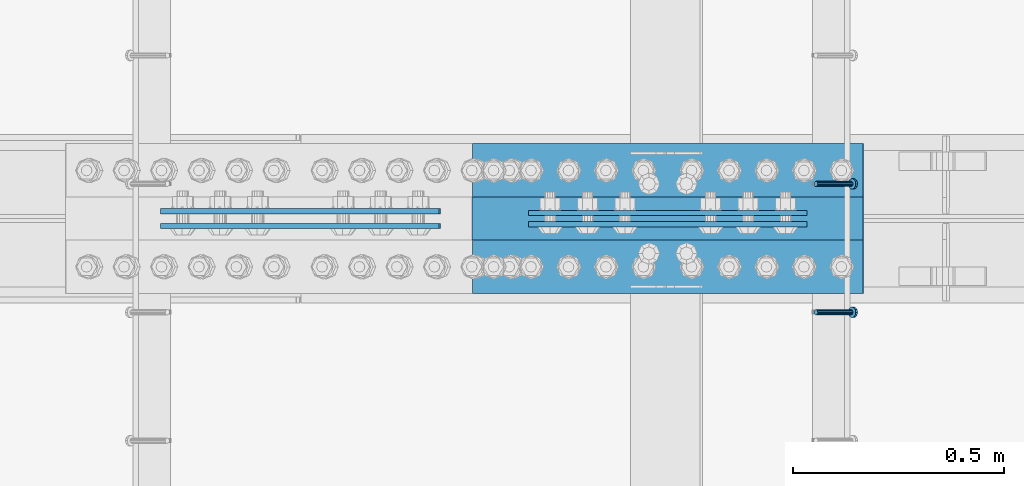
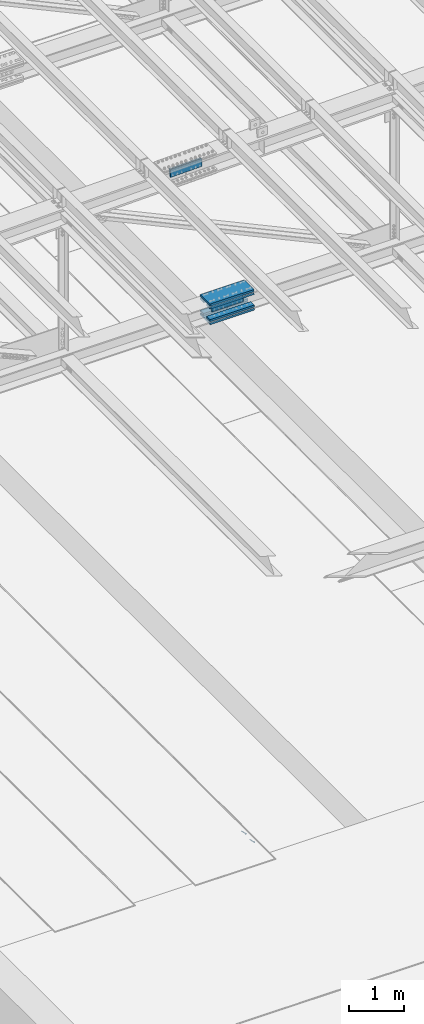
# One storey, part 2426 of 3843: 10 beams, 2 members, 3 elements without a shape of their own.
"""IFC2X3 building model written with IfcOpenShell, lengths in millimetres."""

import ifcopenshell
import ifcopenshell.guid

model = None  # the IFC model being written
_history = None  # IfcOwnerHistory: only IFC2X3 demands one
_inside = {}  # id of a spatial element -> (the spatial element, [elements in it])
_under = {}  # id of a project, library or spatial element -> (it, [spatial elements below it])
_declared = {}  # id of a project -> (the project, [libraries it declares])
_typed = {}  # id of a type object -> (the type object, [elements of that type])
_made_of = {}  # id of a material, layer set ... -> (it, [elements and type objects made of it])


def new_model(schema):
    """Start an empty IFC model of exactly this schema.

    Asked for "IFC4X3", IfcOpenShell would pick the latest addendum, in which some entities
    have other attributes; the version numbers below select the first issue.
    IFC2X3 requires an IfcOwnerHistory on every rooted entity: one is made here for all.
    """
    global model, _history
    if schema == "IFC4X3":
        model = ifcopenshell.file(schema_version=(4, 3, 0, 0))
    else:
        model = ifcopenshell.file(schema=schema)
    _inside.clear()
    _under.clear()
    _declared.clear()
    _typed.clear()
    _made_of.clear()
    _history = None
    if model.schema == "IFC2X3":
        org = make("IfcOrganization", Name="unknown")
        user = make(
            "IfcPersonAndOrganization",
            ThePerson=make("IfcPerson", FamilyName="unknown"),
            TheOrganization=org,
        )
        app = make(
            "IfcApplication",
            ApplicationDeveloper=org,
            Version="unknown",
            ApplicationFullName="unknown",
            ApplicationIdentifier="unknown",
        )
        _history = make(
            "IfcOwnerHistory",
            OwningUser=user,
            OwningApplication=app,
            ChangeAction="ADDED",
            CreationDate=0,
        )
    return model


def make(cls, **values):
    """One entity of the class cls with the attributes given. An attribute that is None is left unset."""
    return model.create_entity(
        cls, **{name: value for name, value in values.items() if value is not None}
    )


def rooted(cls, **values):
    """An entity with a GlobalId (a new one), such as an element, a storey or a relation."""
    return make(cls, GlobalId=ifcopenshell.guid.new(), OwnerHistory=_history, **values)


def si_unit(unit_type, name, prefix=None):
    """IfcSIUnit, for example si_unit("LENGTHUNIT", "METRE", prefix="MILLI")."""
    return make("IfcSIUnit", UnitType=unit_type, Prefix=prefix, Name=name)


def assignment(units):
    """IfcUnitAssignment: the units of a project."""
    return None if units is None else make("IfcUnitAssignment", Units=units)


def point(xyz):
    """IfcCartesianPoint."""
    return None if xyz is None else make("IfcCartesianPoint", Coordinates=xyz)


def direction(xyz):
    """IfcDirection."""
    return None if xyz is None else make("IfcDirection", DirectionRatios=xyz)


def frame(location, z_axis=None, x_axis=None):
    """IfcAxis2Placement3D, a coordinate frame: its origin and axes. An axis left out is left unset."""
    return make(
        "IfcAxis2Placement3D",
        Location=point(location),
        Axis=direction(z_axis),
        RefDirection=direction(x_axis),
    )


def origin_with_axes():
    """The frame at (0, 0, 0) with the z axis (0, 0, 1) and the x axis (1, 0, 0) written out."""
    return frame((0.0, 0.0, 0.0), z_axis=(0.0, 0.0, 1.0), x_axis=(1.0, 0.0, 0.0))


def place(relative_to, where):
    """IfcLocalPlacement: puts the frame where relative to a parent placement (None: the world)."""
    return make(
        "IfcLocalPlacement", PlacementRelTo=relative_to, RelativePlacement=where
    )


def context(
    kind, dimensions, precision=None, world=None, true_north=None, identifier=None
):
    """IfcGeometricRepresentationContext, for example the 3D "Model" context."""
    return make(
        "IfcGeometricRepresentationContext",
        ContextIdentifier=identifier,
        ContextType=kind,
        CoordinateSpaceDimension=dimensions,
        Precision=precision,
        WorldCoordinateSystem=world,
        TrueNorth=true_north,
    )


def subcontext(parent, identifier, kind, view, scale=None):
    """IfcGeometricRepresentationSubContext, for example "Body" below "Model"."""
    return make(
        "IfcGeometricRepresentationSubContext",
        ContextIdentifier=identifier,
        ContextType=kind,
        ParentContext=parent,
        TargetScale=scale,
        TargetView=view,
    )


def project(units=None, contexts=None):
    """IfcProject with its units and contexts."""
    return rooted(
        "IfcProject",
        Name="project",
        RepresentationContexts=contexts,
        UnitsInContext=assignment(units),
    )


def spatial(cls, under=None, at=None, **own):
    """A site, building, storey or space (cls), placed at a placement, below another one or the project."""
    s = rooted(cls, ObjectPlacement=at, **own)
    if under is not None:
        _under.setdefault(under.id(), (under, []))[1].append(s)
    return s


def faces_of(points, faces, orient=None, outer=None):
    """IfcFace entities. A face is a list of loops; a loop is a list of indices into points, from 0.

    orient and outer hold one flag for each loop. By default every Orientation is true, the
    first loop of a face is its IfcFaceOuterBound and the others are IfcFaceBound.
    """
    made = []
    for i, loops in enumerate(faces):
        bounds = []
        for j, loop in enumerate(loops):
            is_outer = j == 0 if outer is None else outer[i][j]
            bounds.append(
                make(
                    "IfcFaceOuterBound" if is_outer else "IfcFaceBound",
                    Bound=make("IfcPolyLoop", Polygon=[points[k] for k in loop]),
                    Orientation=True if orient is None else orient[i][j],
                )
            )
        made.append(make("IfcFace", Bounds=bounds))
    return made


def faceted_brep(points, faces, orient=None, outer=None, voids=None):
    """IfcFacetedBrep: a solid bounded by flat faces; with voids (closed shells), ...WithVoids."""
    shared = [point(p) for p in points]
    hull = make("IfcClosedShell", CfsFaces=faces_of(shared, faces, orient, outer))
    if voids is None:
        return make("IfcFacetedBrep", Outer=hull)
    return make(
        "IfcFacetedBrepWithVoids",
        Outer=hull,
        Voids=[
            make(cls, CfsFaces=faces_of(shared, fs, o, b)) for cls, fs, o, b in voids
        ],
    )


def shape(context_of_items, identifier, shape_type, items):
    """IfcShapeRepresentation: the items that make up one representation, for example the "Body"."""
    return make(
        "IfcShapeRepresentation",
        ContextOfItems=context_of_items,
        RepresentationIdentifier=identifier,
        RepresentationType=shape_type,
        Items=items,
    )


def material(Name=None, Category=None):
    """IfcMaterial."""
    return make("IfcMaterial", Name=Name, Category=Category)


def made_of(thing, what):
    """Note that an element or type object is made of a material, layer set ...; save() writes the relation."""
    if what is not None:
        _made_of.setdefault(what.id(), (what, []))[1].append(thing)
    return thing


def type_object(cls, material=None, **own):
    """A type object (cls), such as IfcWallType, which elements share."""
    return made_of(rooted(cls, **own), material)


def element(
    cls,
    number,
    at=None,
    inside=None,
    cuts=None,
    type_object=None,
    material=None,
    context=None,
    identifier="Body",
    shape_type=None,
    held_by="IfcProductDefinitionShape",
    body=None,
    shapes=None,
    **own,
):
    """One element of the class cls, such as IfcWall. Its Tag is "e" and its number.

    at: its placement. inside: the storey or other place that contains it. cuts: it is an
    opening in that element (IfcRelVoidsElement). A single representation is given by context,
    identifier, shape_type and body (its items); several are given by shapes. held_by: the class
    of the entity that holds the representations. save() writes the other relations.
    """
    e = rooted(cls, Tag="e%d" % number, ObjectPlacement=at, **own)
    if body is not None:
        shapes = [shape(context, identifier, shape_type, body)]
    if shapes is not None:
        e.Representation = make(held_by, Representations=shapes)
    if inside is not None:
        _inside.setdefault(inside.id(), (inside, []))[1].append(e)
    if cuts is not None:
        rooted(
            "IfcRelVoidsElement", RelatingBuildingElement=cuts, RelatedOpeningElement=e
        )
    if type_object is not None:
        _typed.setdefault(type_object.id(), (type_object, []))[1].append(e)
    return made_of(e, material)


def aggregate(whole, parts):
    """IfcRelAggregates: a whole, such as a stair, and the parts it consists of."""
    return rooted("IfcRelAggregates", RelatingObject=whole, RelatedObjects=parts)


def save(model, path):
    """Write the relations noted so far, then the file.

    IfcRelAggregates (storeys below a building ...), IfcRelContainedInSpatialStructure (elements
    in a storey), IfcRelDefinesByType, IfcRelAssociatesMaterial and IfcRelDeclares: one each for
    every whole, place, type object, material and project.
    """
    for whole, parts in _under.values():
        aggregate(whole, parts)
    for where, things in _inside.values():
        rooted(
            "IfcRelContainedInSpatialStructure",
            RelatedElements=things,
            RelatingStructure=where,
        )
    for kind, things in _typed.values():
        rooted("IfcRelDefinesByType", RelatedObjects=things, RelatingType=kind)
    for what, things in _made_of.values():
        rooted("IfcRelAssociatesMaterial", RelatedObjects=things, RelatingMaterial=what)
    for by, libraries in _declared.values():
        rooted("IfcRelDeclares", RelatingContext=by, RelatedDefinitions=libraries)
    model.write(path)


model = new_model("IFC2X3")

# Units and contexts
model_context = context("Model", 3, precision=1e-05, world=origin_with_axes())
body_context = subcontext(model_context, "Body", "Model", "MODEL_VIEW")
ifc_project = project(units=[si_unit("LENGTHUNIT", "METRE", prefix="MILLI"), si_unit("AREAUNIT", "SQUARE_METRE"), si_unit("VOLUMEUNIT", "CUBIC_METRE"), si_unit("MASSUNIT", "GRAM", prefix="KILO"), si_unit("TIMEUNIT", "SECOND"), si_unit("PLANEANGLEUNIT", "RADIAN"), si_unit("SOLIDANGLEUNIT", "STERADIAN"), si_unit("THERMODYNAMICTEMPERATUREUNIT", "DEGREE_CELSIUS"), si_unit("LUMINOUSINTENSITYUNIT", "LUMEN")], contexts=[model_context])

# Site, building, storey
site_placement = place(None, origin_with_axes())
site = spatial("IfcSite", under=ifc_project, at=site_placement, CompositionType="ELEMENT")
building_placement = place(site_placement, origin_with_axes())
building = spatial("IfcBuilding", under=site, at=building_placement, Name="Undefined", CompositionType="ELEMENT")
storey_placement = place(building_placement, origin_with_axes())
storey = spatial("IfcBuildingStorey", under=building, at=storey_placement, Name="Undefined", CompositionType="ELEMENT", Elevation=0.0)

# Assembly, members
assembly_1_placement = place(storey_placement, origin_with_axes())
assembly_1 = element("IfcElementAssembly", 1, at=assembly_1_placement, inside=storey, Name="EMBED_ANGLE", AssemblyPlace="NOTDEFINED", PredefinedType="RIGID_FRAME")
ifc_material_1 = material(Name="STEEL/A108")
member_type = type_object("IfcMemberType", PredefinedType="NOTDEFINED")
member_1_placement = place(assembly_1_placement, frame((52815.2995, 67049.649703125, 30446.6625), z_axis=(0.0, 1.0, 0.0), x_axis=(0.707106781186548, 0.0, -0.707106781186548)))
member_1 = element("IfcMember", 2, at=member_1_placement, type_object=member_type, material=ifc_material_1, Name="HEADED STUD ANCHOR", context=body_context, shape_type="Brep", body=[
    faceted_brep([(7.27595761418343e-12, -3.18000006675175, 5.5), (0.0, -5.49999999998363, 3.1800000667572), (118.110000000976, -5.49999999999091, 3.1800000667572), (118.110000000983, -3.18000006675175, 5.5), (0.0, -6.3499999046162, 0.0), (118.110000000968, -6.34999990461256, 0.0), (0.0, -5.49999999998363, -3.1800000667572), (118.110000000976, -5.49999999999091, -3.1800000667572), (7.27595761418343e-12, -3.18000006675175, -5.5), (118.110000000983, -3.18000006675175, -5.5), (7.27595761418343e-12, -1.81898940354586e-12, -6.34999990463257), (118.110000000968, -1.81898940354586e-12, -6.34999990463257), (0.0, 3.18000006675175, -5.5), (118.110000000968, 3.18000006674811, -5.5), (7.27595761418343e-12, 5.49999999998363, -3.1800000667572), (118.110000000983, 5.49999999998363, -3.1800000667572), (7.27595761418343e-12, 6.3499999046162, 0.0), (118.110000000976, 6.34999990461256, 0.0), (7.27595761418343e-12, 5.49999999998363, 3.1800000667572), (118.110000000983, 5.49999999998363, 3.1800000667572), (0.0, 3.18000006675175, 5.5), (118.110000000968, 3.18000006674811, 5.5), (7.27595761418343e-12, -1.81898940354586e-12, 6.34999990463257), (118.110000000968, -1.81898940354586e-12, 6.34999990463257), (120.650000000991, -10.9899997710909, 6.34999990463257), (120.650000000998, -6.34000015257152, 10.9899997711182), (120.650000000991, -12.6999998092379, 0.0), (120.650000000991, -10.9899997710909, -6.34999990463257), (120.650000000998, -6.34000015257152, -10.9899997711182), (120.650000000991, -1.81898940354586e-12, -12.6899995803833), (120.650000000991, 6.34000015257152, -10.9899997711182), (120.650000000998, 10.9899997710909, -6.34999990463257), (120.650000000991, 12.6999998092342, 0.0), (120.650000000998, 10.9899997710909, 6.34999990463257), (120.650000000991, 6.34000015257152, 10.9899997711182), (120.650000000991, -1.81898940354586e-12, 12.6899995803833), (127.000000001048, -10.9899997710945, 6.34999990463257), (127.000000001048, -6.34000015257152, 10.9899997711182), (127.000000001048, -12.6999998092342, 0.0), (127.000000001048, -10.9899997710945, -6.34999990463257), (127.000000001048, -6.34000015257152, -10.9899997711182), (127.000000001048, 1.81898940354586e-12, -12.6899995803833), (127.000000001048, 6.34000015256788, -10.9899997711182), (127.000000001048, 10.9899997710909, -6.34999990463257), (127.000000001048, 12.6999998092379, 0.0), (127.000000001048, 10.9899997710909, 6.34999990463257), (127.000000001048, 6.34000015256788, 10.9899997711182), (127.000000001048, 1.81898940354586e-12, 12.6899995803833)], [[[0, 1, 2, 3]], [[1, 4, 5, 2]], [[4, 6, 7, 5]], [[6, 8, 9, 7]], [[8, 10, 11, 9]], [[10, 12, 13, 11]], [[12, 14, 15, 13]], [[14, 16, 17, 15]], [[16, 18, 19, 17]], [[18, 20, 21, 19]], [[20, 22, 23, 21]], [[22, 0, 3, 23]], [[22, 20, 18, 16, 14, 12, 10, 8, 6, 4, 1, 0]], [[3, 2, 24, 25]], [[2, 5, 26, 24]], [[5, 7, 27, 26]], [[7, 9, 28, 27]], [[9, 11, 29, 28]], [[11, 13, 30, 29]], [[13, 15, 31, 30]], [[15, 17, 32, 31]], [[17, 19, 33, 32]], [[19, 21, 34, 33]], [[21, 23, 35, 34]], [[23, 3, 25, 35]], [[25, 24, 36, 37]], [[24, 26, 38, 36]], [[26, 27, 39, 38]], [[27, 28, 40, 39]], [[28, 29, 41, 40]], [[29, 30, 42, 41]], [[30, 31, 43, 42]], [[31, 32, 44, 43]], [[32, 33, 45, 44]], [[33, 34, 46, 45]], [[34, 35, 47, 46]], [[35, 25, 37, 47]], [[38, 39, 40, 41, 42, 43, 44, 45, 46, 47, 37, 36]]]),
])
member_2_placement = place(assembly_1_placement, frame((52815.2995, 67354.449703125, 30446.6625), z_axis=(0.0, 1.0, 0.0), x_axis=(0.707106781186548, 0.0, -0.707106781186548)))
member_2 = element("IfcMember", 3, at=member_2_placement, type_object=member_type, material=ifc_material_1, Name="HEADED STUD ANCHOR", context=body_context, shape_type="Brep", body=[
    faceted_brep([(7.27595761418343e-12, -3.18000006675175, 5.5), (0.0, -5.49999999998363, 3.1800000667572), (118.110000000976, -5.49999999999091, 3.1800000667572), (118.110000000983, -3.18000006675175, 5.5), (0.0, -6.3499999046162, 0.0), (118.110000000968, -6.34999990461256, 0.0), (0.0, -5.49999999998363, -3.1800000667572), (118.110000000976, -5.49999999999091, -3.1800000667572), (7.27595761418343e-12, -3.18000006675175, -5.5), (118.110000000983, -3.18000006675175, -5.5), (7.27595761418343e-12, -1.81898940354586e-12, -6.34999990463257), (118.110000000968, -1.81898940354586e-12, -6.34999990463257), (0.0, 3.18000006675175, -5.5), (118.110000000968, 3.18000006674811, -5.5), (7.27595761418343e-12, 5.49999999998363, -3.1800000667572), (118.110000000983, 5.49999999998363, -3.1800000667572), (7.27595761418343e-12, 6.3499999046162, 0.0), (118.110000000976, 6.34999990461256, 0.0), (7.27595761418343e-12, 5.49999999998363, 3.1800000667572), (118.110000000983, 5.49999999998363, 3.1800000667572), (0.0, 3.18000006675175, 5.5), (118.110000000968, 3.18000006674811, 5.5), (7.27595761418343e-12, -1.81898940354586e-12, 6.34999990463257), (118.110000000968, -1.81898940354586e-12, 6.34999990463257), (120.650000000991, -10.9899997710909, 6.34999990463257), (120.650000000998, -6.34000015257152, 10.9899997711182), (120.650000000991, -12.6999998092379, 0.0), (120.650000000991, -10.9899997710909, -6.34999990463257), (120.650000000998, -6.34000015257152, -10.9899997711182), (120.650000000991, -1.81898940354586e-12, -12.6899995803833), (120.650000000991, 6.34000015257152, -10.9899997711182), (120.650000000998, 10.9899997710909, -6.34999990463257), (120.650000000991, 12.6999998092342, 0.0), (120.650000000998, 10.9899997710909, 6.34999990463257), (120.650000000991, 6.34000015257152, 10.9899997711182), (120.650000000991, -1.81898940354586e-12, 12.6899995803833), (127.000000001048, -10.9899997710945, 6.34999990463257), (127.000000001048, -6.34000015257152, 10.9899997711182), (127.000000001048, -12.6999998092342, 0.0), (127.000000001048, -10.9899997710945, -6.34999990463257), (127.000000001048, -6.34000015257152, -10.9899997711182), (127.000000001048, 1.81898940354586e-12, -12.6899995803833), (127.000000001048, 6.34000015256788, -10.9899997711182), (127.000000001048, 10.9899997710909, -6.34999990463257), (127.000000001048, 12.6999998092379, 0.0), (127.000000001048, 10.9899997710909, 6.34999990463257), (127.000000001048, 6.34000015256788, 10.9899997711182), (127.000000001048, 1.81898940354586e-12, 12.6899995803833)], [[[0, 1, 2, 3]], [[1, 4, 5, 2]], [[4, 6, 7, 5]], [[6, 8, 9, 7]], [[8, 10, 11, 9]], [[10, 12, 13, 11]], [[12, 14, 15, 13]], [[14, 16, 17, 15]], [[16, 18, 19, 17]], [[18, 20, 21, 19]], [[20, 22, 23, 21]], [[22, 0, 3, 23]], [[22, 20, 18, 16, 14, 12, 10, 8, 6, 4, 1, 0]], [[3, 2, 24, 25]], [[2, 5, 26, 24]], [[5, 7, 27, 26]], [[7, 9, 28, 27]], [[9, 11, 29, 28]], [[11, 13, 30, 29]], [[13, 15, 31, 30]], [[15, 17, 32, 31]], [[17, 19, 33, 32]], [[19, 21, 34, 33]], [[21, 23, 35, 34]], [[23, 3, 25, 35]], [[25, 24, 36, 37]], [[24, 26, 38, 36]], [[26, 27, 39, 38]], [[27, 28, 40, 39]], [[28, 29, 41, 40]], [[29, 30, 42, 41]], [[30, 31, 43, 42]], [[31, 32, 44, 43]], [[32, 33, 45, 44]], [[33, 34, 46, 45]], [[34, 35, 47, 46]], [[35, 25, 37, 47]], [[38, 39, 40, 41, 42, 43, 44, 45, 46, 47, 37, 36]]]),
])
aggregate(assembly_1, [member_1, member_2])

# Assembly, beam
assembly_2_placement = place(storey_placement, origin_with_axes())
assembly_2 = element("IfcElementAssembly", 4, at=assembly_2_placement, inside=storey, Name="BEAM", AssemblyPlace="NOTDEFINED", PredefinedType="RIGID_FRAME")
ifc_material_2 = material(Name="STEEL/A572-50")
beam_type_1 = type_object("IfcBeamType", PredefinedType="NOTDEFINED")
beam_1_placement = place(assembly_2_placement, frame((52793.8984726078, 67258.40625, 42320.5850515071), z_axis=(0.00308226299943634, 0.0, -0.999995249816119), x_axis=(-0.999995249816119, 0.0, -0.00308226299943732)))
beam_1 = element("IfcBeam", 5, at=beam_1_placement, type_object=beam_type_1, material=ifc_material_2, Name="PLATE", context=body_context, shape_type="Brep", body=[
    faceted_brep([(1.45519152283669e-11, 6.35000000000582, -88.8999999998996), (0.0, 6.34999999999854, 88.9000015258789), (660.399999982677, 6.35000000000582, 88.8999999999651), (660.399999982707, 6.35000000000582, -88.8999999998268), (0.0, -6.34999999999854, 88.9000015258789), (660.399999982677, -6.35000000000582, 88.8999999999651), (1.45519152283669e-11, -6.35000000000582, -88.8999999998996), (660.399999982707, -6.35000000000582, -88.8999999998268)], [[[0, 1, 2, 3]], [[1, 4, 5, 2]], [[4, 6, 7, 5]], [[6, 0, 3, 7]], [[5, 7, 3, 2]], [[6, 4, 1, 0]]]),
])

# Assembly, beams
assembly_3_placement = place(storey_placement, origin_with_axes())
assembly_3 = element("IfcElementAssembly", 6, at=assembly_3_placement, inside=storey, Name="BEAM", AssemblyPlace="NOTDEFINED", PredefinedType="RIGID_FRAME")
beam_2_placement = place(assembly_3_placement, frame((51922.3046035143, 67289.3625, 45617.4714041232), z_axis=(0.0243978430079077, 0.0, -0.999702328324067), x_axis=(-0.999702328324067, 0.0, -0.024397843007905)))
beam_2 = element("IfcBeam", 7, at=beam_2_placement, type_object=beam_type_1, material=ifc_material_2, Name="PLATE", context=body_context, shape_type="Brep", body=[
    faceted_brep([(1.45519152283669e-11, 6.35000000000582, -88.8999999998996), (0.0, 6.34999999999854, 88.9000015258789), (660.399999982677, 6.35000000000582, 88.8999999999651), (660.399999982707, 6.35000000000582, -88.8999999998268), (0.0, -6.34999999999854, 88.9000015258789), (660.399999982677, -6.35000000000582, 88.8999999999651), (1.45519152283669e-11, -6.35000000000582, -88.8999999998996), (660.399999982707, -6.35000000000582, -88.8999999998268)], [[[0, 1, 2, 3]], [[1, 4, 5, 2]], [[4, 6, 7, 5]], [[6, 0, 3, 7]], [[5, 7, 3, 2]], [[6, 4, 1, 0]]]),
])
beam_3_placement = place(assembly_3_placement, frame((51922.3046035143, 67254.4375, 45617.4714041232), z_axis=(0.0243978430079077, 0.0, -0.999702328324067), x_axis=(-0.999702328324067, 0.0, -0.024397843007905)))
beam_3 = element("IfcBeam", 8, at=beam_3_placement, type_object=beam_type_1, material=ifc_material_2, Name="PLATE", context=body_context, shape_type="Brep", body=[
    faceted_brep([(1.45519152283669e-11, 6.35000000000582, -88.8999999998996), (0.0, 6.34999999999854, 88.9000015258789), (660.399999982677, 6.35000000000582, 88.8999999999651), (660.399999982707, 6.35000000000582, -88.8999999998268), (0.0, -6.34999999999854, 88.9000015258789), (660.399999982677, -6.35000000000582, 88.8999999999651), (1.45519152283669e-11, -6.35000000000582, -88.8999999998996), (660.399999982707, -6.35000000000582, -88.8999999998268)], [[[0, 1, 2, 3]], [[1, 4, 5, 2]], [[4, 6, 7, 5]], [[6, 0, 3, 7]], [[5, 7, 3, 2]], [[6, 4, 1, 0]]]),
])
aggregate(assembly_3, [beam_2, beam_3])

# Beam
beam_4_placement = place(assembly_2_placement, frame((52793.8984726078, 67285.39375, 42320.5850515071), z_axis=(0.00308226299943634, 0.0, -0.999995249816119), x_axis=(-0.999995249816119, 0.0, -0.00308226299943732)))
beam_4 = element("IfcBeam", 9, at=beam_4_placement, type_object=beam_type_1, material=ifc_material_2, Name="PLATE", context=body_context, shape_type="Brep", body=[
    faceted_brep([(1.45519152283669e-11, 6.35000000000582, -88.8999999998996), (0.0, 6.34999999999854, 88.9000015258789), (660.399999982677, 6.35000000000582, 88.8999999999651), (660.399999982707, 6.35000000000582, -88.8999999998268), (0.0, -6.34999999999854, 88.9000015258789), (660.399999982677, -6.35000000000582, 88.8999999999651), (1.45519152283669e-11, -6.35000000000582, -88.8999999998996), (660.399999982707, -6.35000000000582, -88.8999999998268)], [[[0, 1, 2, 3]], [[1, 4, 5, 2]], [[4, 6, 7, 5]], [[6, 0, 3, 7]], [[5, 7, 3, 2]], [[6, 4, 1, 0]]]),
])

beam_type_2 = type_object("IfcBeamType", PredefinedType="NOTDEFINED")
beam_5_placement = place(assembly_2_placement, frame((52926.6117401026, 67271.9, 42527.3691308405), z_axis=(0.0, -1.0, 0.0), x_axis=(-0.999995249816119, 0.0, -0.00308226299943732)))
beam_5 = element("IfcBeam", 10, at=beam_5_placement, type_object=beam_type_2, material=ifc_material_2, Name="PLATE", context=body_context, shape_type="Brep", body=[
    faceted_brep([(0.0, 22.2249999999767, -177.800000000003), (0.0, 22.2249999999767, 177.800000000003), (927.099999958984, 22.2250000000859, 177.800000000003), (927.099999958984, 22.2250000000859, -177.800000000003), (0.0, -22.2249999999694, 177.800000000003), (927.099999958984, -22.2249999998749, 177.800000000003), (0.0, -22.2249999999694, -177.800000000003), (927.099999958984, -22.2249999998749, -177.800000000003)], [[[0, 1, 2, 3]], [[1, 4, 5, 2]], [[4, 6, 7, 5]], [[6, 0, 3, 7]], [[5, 7, 3, 2]], [[6, 4, 1, 0]]]),
])

beam_6_placement = place(assembly_2_placement, frame((52927.8875456511, 67271.9, 42114.5544722647), z_axis=(0.0, -1.0, 0.0), x_axis=(-0.999995249816119, 0.0, -0.00308226299943732)))
beam_6 = element("IfcBeam", 11, at=beam_6_placement, type_object=beam_type_2, material=ifc_material_2, Name="PLATE", context=body_context, shape_type="Brep", body=[
    faceted_brep([(0.0, 22.2249999999767, -177.800000000003), (0.0, 22.2249999999767, 177.800000000003), (927.099999958984, 22.2250000000859, 177.800000000003), (927.099999958984, 22.2250000000859, -177.800000000003), (0.0, -22.2249999999694, 177.800000000003), (927.099999958984, -22.2249999998749, 177.800000000003), (0.0, -22.2249999999694, -177.800000000003), (927.099999958984, -22.2249999998749, -177.800000000003)], [[[0, 1, 2, 3]], [[1, 4, 5, 2]], [[4, 6, 7, 5]], [[6, 0, 3, 7]], [[5, 7, 3, 2]], [[6, 4, 1, 0]]]),
])

beam_type_3 = type_object("IfcBeamType", PredefinedType="NOTDEFINED")
beam_7_placement = place(assembly_2_placement, frame((51999.7267600347, 67386.2, 42456.1802609551), z_axis=(0.0, -1.0, 0.0), x_axis=(0.999995249816119, 0.0, 0.00308226299943554)))
beam_7 = element("IfcBeam", 12, at=beam_7_placement, type_object=beam_type_3, material=ifc_material_2, Name="PLATE", context=body_context, shape_type="Brep", body=[
    faceted_brep([(-7.27595761418343e-11, 22.2250000000786, -63.5), (-7.27595761418343e-11, 22.2250000000786, 63.5), (927.099999951592, 22.2250000031054, 63.5), (927.099999951592, 22.2250000031054, -63.5), (6.54836185276508e-11, -22.2250000000713, 63.5), (927.099999951744, -22.2249999970372, 63.5), (6.54836185276508e-11, -22.2250000000713, -63.5), (927.099999951744, -22.2249999970372, -63.5)], [[[0, 1, 2, 3]], [[1, 4, 5, 2]], [[4, 6, 7, 5]], [[6, 0, 3, 7]], [[5, 7, 3, 2]], [[6, 4, 1, 0]]]),
])

beam_8_placement = place(assembly_2_placement, frame((52000.5781504334, 67386.2, 42179.9590719878), z_axis=(0.0, -1.0, 0.0), x_axis=(0.999995249816119, 0.0, 0.00308226299943554)))
beam_8 = element("IfcBeam", 13, at=beam_8_placement, type_object=beam_type_3, material=ifc_material_2, Name="PLATE", context=body_context, shape_type="Brep", body=[
    faceted_brep([(-7.27595761418343e-11, 22.2250000000786, -63.5), (-7.27595761418343e-11, 22.2250000000786, 63.5), (927.099999951592, 22.2250000031054, 63.5), (927.099999951592, 22.2250000031054, -63.5), (6.54836185276508e-11, -22.2250000000713, 63.5), (927.099999951744, -22.2249999970372, 63.5), (6.54836185276508e-11, -22.2250000000713, -63.5), (927.099999951744, -22.2249999970372, -63.5)], [[[0, 1, 2, 3]], [[1, 4, 5, 2]], [[4, 6, 7, 5]], [[6, 0, 3, 7]], [[5, 7, 3, 2]], [[6, 4, 1, 0]]]),
])

beam_9_placement = place(assembly_2_placement, frame((51999.7267600347, 67157.6, 42456.1802609551), z_axis=(0.0, -1.0, 0.0), x_axis=(0.999995249816119, 0.0, 0.00308226299943554)))
beam_9 = element("IfcBeam", 14, at=beam_9_placement, type_object=beam_type_3, material=ifc_material_2, Name="PLATE", context=body_context, shape_type="Brep", body=[
    faceted_brep([(-7.27595761418343e-11, 22.2250000000786, -63.5), (-7.27595761418343e-11, 22.2250000000786, 63.5), (927.099999951592, 22.2250000031054, 63.5), (927.099999951592, 22.2250000031054, -63.5), (6.54836185276508e-11, -22.2250000000713, 63.5), (927.099999951744, -22.2249999970372, 63.5), (6.54836185276508e-11, -22.2250000000713, -63.5), (927.099999951744, -22.2249999970372, -63.5)], [[[0, 1, 2, 3]], [[1, 4, 5, 2]], [[4, 6, 7, 5]], [[6, 0, 3, 7]], [[5, 7, 3, 2]], [[6, 4, 1, 0]]]),
])

beam_10_placement = place(assembly_2_placement, frame((52000.5781504334, 67157.6, 42179.9590719878), z_axis=(0.0, -1.0, 0.0), x_axis=(0.999995249816119, 0.0, 0.00308226299943554)))
beam_10 = element("IfcBeam", 15, at=beam_10_placement, type_object=beam_type_3, material=ifc_material_2, Name="PLATE", context=body_context, shape_type="Brep", body=[
    faceted_brep([(-7.27595761418343e-11, 22.2250000000786, -63.5), (-7.27595761418343e-11, 22.2250000000786, 63.5), (927.099999951592, 22.2250000031054, 63.5), (927.099999951592, 22.2250000031054, -63.5), (6.54836185276508e-11, -22.2250000000713, 63.5), (927.099999951744, -22.2249999970372, 63.5), (6.54836185276508e-11, -22.2250000000713, -63.5), (927.099999951744, -22.2249999970372, -63.5)], [[[0, 1, 2, 3]], [[1, 4, 5, 2]], [[4, 6, 7, 5]], [[6, 0, 3, 7]], [[5, 7, 3, 2]], [[6, 4, 1, 0]]]),
])

aggregate(assembly_2, [beam_1, beam_5, beam_7, beam_8, beam_9, beam_10, beam_4, beam_6])

save(model, "model.ifc")
